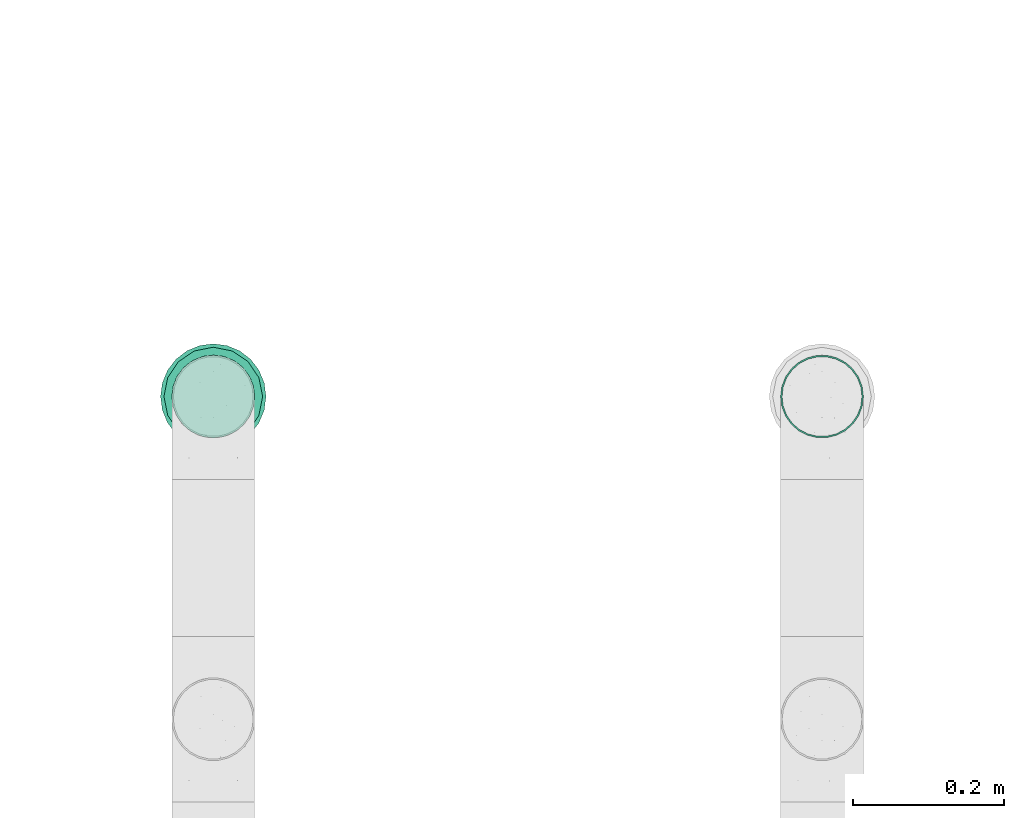
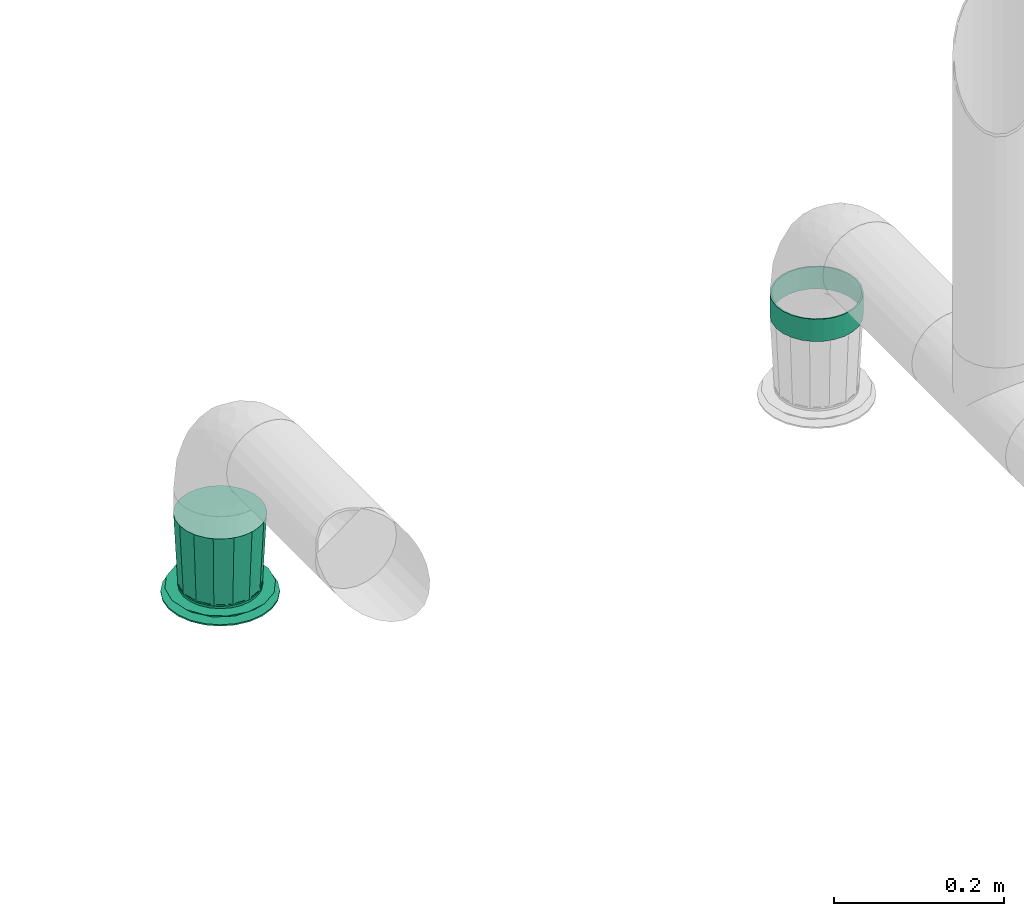
# One storey, part 33 of 103: 1 flow fitting, 1 flow segment, 1 flow terminal.
"""IFC2X3 building model written with IfcOpenShell, lengths in millimetres."""

from ifc_helpers import new_model, entity, si_unit, converted_unit, derived_unit, direction, frame, origin_with_axes, origin_2d_with_axis, place, context, subcontext, project, spatial, hollow_circle, extrude, open_shell, surface_model, source, transform, mapped, material, layer, layer_set, layer_usage, type_object, element, save


model = new_model("IFC2X3")

# Units and contexts
model_context = context("Model", 3, precision=1e-05, world=origin_with_axes(), true_north=direction((0.0, 1.0)))
body_context = subcontext(model_context, "Body", "Model", "MODEL_VIEW")
ifc_project = project(units=[si_unit("AREAUNIT", "SQUARE_METRE"), si_unit("VOLUMEUNIT", "CUBIC_METRE", prefix="DECI"), si_unit("TIMEUNIT", "SECOND"), si_unit("THERMODYNAMICTEMPERATUREUNIT", "DEGREE_CELSIUS"), si_unit("PRESSUREUNIT", "PASCAL"), si_unit("MASSUNIT", "GRAM", prefix="KILO"), si_unit("LENGTHUNIT", "METRE", prefix="MILLI"), si_unit("POWERUNIT", "WATT"), si_unit("ELECTRICCURRENTUNIT", "AMPERE"), si_unit("ELECTRICVOLTAGEUNIT", "VOLT"), derived_unit("VOLUMETRICFLOWRATEUNIT", [(si_unit("VOLUMEUNIT", "CUBIC_METRE", prefix="DECI"), 1), (si_unit("TIMEUNIT", "SECOND"), -1)]), derived_unit("LINEARVELOCITYUNIT", [(si_unit("LENGTHUNIT", "METRE"), 1), (si_unit("TIMEUNIT", "SECOND"), -1)]), derived_unit("MASSDENSITYUNIT", [(si_unit("MASSUNIT", "GRAM", prefix="KILO"), 1), (si_unit("VOLUMEUNIT", "CUBIC_METRE"), -1)]), converted_unit("PLANEANGLEUNIT", "DEGREE", entity("IfcRatioMeasure", 0.01745), si_unit("PLANEANGLEUNIT", "RADIAN"), dimensions=[0, 0, 0, 0, 0, 0, 0])], contexts=[model_context])

# Site, building, storey
site_placement = place(None, origin_with_axes())
site = spatial("IfcSite", under=ifc_project, at=site_placement, CompositionType="ELEMENT")
building_placement = place(site_placement, origin_with_axes())
building = spatial("IfcBuilding", under=site, at=building_placement, Name="mc-building", CompositionType="ELEMENT")
storey_placement = place(building_placement, frame((0.0, 0.0, 5900.0), z_axis=(0.0, 0.0, 1.0), x_axis=(1.0, 0.0, 0.0)))
storey = spatial("IfcBuildingStorey", under=building, at=storey_placement, Name="3. Korrus", CompositionType="ELEMENT", Elevation=5900.0)

# Flow segment
ifc_material = material(Name="FZ1")
ifc_layer = layer(ifc_material, 0.0)
ifc_layer_set = layer_set([ifc_layer], Name="FZ1")
ifc_layer_usage = layer_usage(ifc_layer_set, "AXIS1", "POSITIVE", 0.0)
duct_segment_type = type_object("IfcDuctSegmentType", PredefinedType="RIGIDSEGMENT")
shared_shape_1 = source(origin_with_axes(), body_context, "Body", "SweptSolid", [
    extrude(hollow_circle(Radius=55.0, WallThickness=2.0, at=origin_2d_with_axis()), frame((0.0, 0.0, 0.0), z_axis=(1.0, 0.0, 0.0), x_axis=(0.0, 1.0, 0.0)), (0.0, 0.0, 1.0), 31.9),
])
flow_segment_placement = place(storey_placement, frame((16394.13313, 4730.85862, 2235.0), z_axis=(0.0, -1.0, 0.0), x_axis=(0.0, 0.0, -1.0)))
element("IfcFlowSegment", 1, at=flow_segment_placement, inside=storey, type_object=duct_segment_type, material=ifc_layer_usage, context=body_context, shape_type="MappedRepresentation", body=[
    mapped(shared_shape_1, transform((0.0, 0.0, 0.0), scale=1.0)),
])

# Flow terminal
air_terminal_type = type_object("IfcAirTerminalType", Name="100", PredefinedType="NOTDEFINED")
shared_shape_2 = source(origin_with_axes(), body_context, "Body", "SurfaceModel", [
    surface_model("IfcShellBasedSurfaceModel", [(11.2, -70.0, 0.0), (11.2, -67.61481, -18.11733), (11.2, -67.61481, 18.11733), (6.2, -14.64625, -20.15883), (9.2, -22.36867, -22.36867), (6.2, -21.19625, -15.39997), (9.2, 16.375, -28.36233), (6.2, 8.09625, -24.91768), (6.2, 14.64625, -20.15883), (6.2, -8.09625, -24.91768), (9.2, -16.375, -28.36233), (6.2, 21.19625, -15.39997), (9.2, 22.36867, -22.36867), (9.2, -8.1875, -30.55617), (9.2, 8.1875, -30.55617), (9.2, 28.36233, -16.375), (9.2, -28.36233, -16.375), (6.2, 14.64625, 20.15883), (9.2, 22.36867, 22.36867), (6.2, 21.19625, 15.39997), (9.2, -16.375, 28.36233), (6.2, -8.09625, 24.91768), (6.2, -14.64625, 20.15883), (6.2, 8.09625, 24.91768), (9.2, 16.375, 28.36233), (6.2, -21.19625, 15.39997), (9.2, -22.36867, 22.36867), (9.2, 8.1875, 30.55617), (9.2, -8.1875, 30.55617), (9.2, -28.36233, 16.375), (9.2, 28.36233, 16.375), (6.2, -53.11211, -25.57744), (6.2, -36.75472, -46.08897), (6.2, -13.11761, -57.472), (6.2, 13.11761, -57.472), (6.2, 36.75472, -46.08897), (6.2, 53.11211, -25.57744), (0.0, -12.53288, -63.00706), (6.2, 0.0, -57.472), (0.0, -46.3155, -46.3155), (0.0, -35.69063, -53.4148), (0.0, 0.0, -65.5), (6.2, 44.93342, -35.83321), (0.0, 46.3155, -46.3155), (0.0, 35.69063, -53.4148), (6.2, -44.93342, -35.83321), (0.0, 12.53288, -63.00706), (0.0, 25.06576, -60.51411), (6.2, 56.03105, -12.78872), (0.0, 60.51411, -25.06576), (0.0, 63.00706, -12.53288), (0.0, 53.4148, -35.69063), (0.0, -25.06576, -60.51411), (0.0, -63.00706, -12.53288), (0.0, -60.51411, -25.06576), (6.2, -56.03105, -12.78872), (0.0, -53.4148, -35.69063), (6.2, 13.11761, 57.472), (0.0, 12.53288, 63.00706), (6.2, 0.0, 57.472), (6.2, 36.75472, 46.08897), (0.0, 46.3155, 46.3155), (0.0, 35.69063, 53.4148), (0.0, 0.0, 65.5), (6.2, -44.93342, 35.83321), (6.2, -36.75472, 46.08897), (0.0, -46.3155, 46.3155), (0.0, -35.69063, 53.4148), (6.2, 44.93342, 35.83321), (0.0, -12.53288, 63.00706), (0.0, -25.06576, 60.51411), (6.2, -13.11761, 57.472), (6.2, -56.03105, 12.78872), (0.0, -60.51411, 25.06576), (0.0, -63.00706, 12.53288), (0.0, -53.4148, 35.69063), (0.0, 25.06576, 60.51411), (0.0, 63.00706, 12.53288), (0.0, 60.51411, 25.06576), (6.2, 56.03105, 12.78872), (0.0, 53.4148, 35.69063), (-3.1, 43.30127, 25.0), (-3.1, -48.29629, -12.94095), (-3.1, -43.30127, 25.0), (-3.1, 25.0, -43.30127), (-3.1, 48.29629, -12.94095), (-3.1, 35.35534, -35.35534), (-3.1, -35.35534, -35.35534), (-3.1, -25.0, -43.30127), (-43.1, 43.46666, 11.64686), (-3.1, 38.97115, 22.5), (-3.1, 43.46666, 11.64686), (-3.1, 45.0, 0.0), (-43.1, 45.0, 0.0), (-3.1, 31.81981, 31.81981), (-43.1, 38.97115, 22.5), (-43.1, -38.97115, 22.5), (-3.1, -38.97115, 22.5), (-3.1, -31.81981, 31.81981), (-3.1, -43.46666, 11.64686), (-43.1, -43.46666, 11.64686), (-43.1, -45.0, 0.0), (-3.1, -45.0, 0.0), (-43.1, -43.46666, -11.64686), (-3.1, -38.97115, -22.5), (-3.1, -43.46666, -11.64686), (-3.1, -11.64686, -43.46666), (-3.1, -22.5, -38.97115), (-43.1, -22.5, -38.97115), (-3.1, -31.81981, -31.81981), (-43.1, -38.97115, -22.5), (-43.1, 22.5, -38.97115), (-3.1, 22.5, -38.97115), (-3.1, 11.64686, -43.46666), (-43.1, 38.97115, -22.5), (-3.1, 38.97115, -22.5), (-3.1, 31.81981, -31.81981), (-3.1, 43.46666, -11.64686), (-43.1, 43.46666, -11.64686), (11.2, -49.49747, -49.49747), (11.2, -35.0, -60.62178), (11.2, -18.11733, -67.61481), (11.2, 67.61481, 18.11733), (11.2, -60.62178, -35.0), (11.2, 18.11733, -67.61481), (11.2, 35.0, -60.62178), (11.2, 0.0, -70.0), (11.2, 60.62178, -35.0), (11.2, 67.61481, -18.11733), (11.2, 49.49747, -49.49747), (11.2, -49.49747, 49.49747), (11.2, -60.62178, 35.0), (11.2, -35.0, 60.62178), (11.2, -18.11733, 67.61481), (11.2, 0.0, 70.0), (11.2, 60.62178, 35.0), (11.2, 49.49747, 49.49747), (11.2, 70.0, 0.0), (11.2, 35.0, 60.62178), (11.2, 18.11733, 67.61481), (9.2, -49.49747, 49.49747), (9.2, -35.0, 60.62178), (9.2, -18.11733, 67.61481), (9.2, -67.61481, 18.11733), (9.2, -70.0, 0.0), (9.2, -60.62178, 35.0), (9.2, 67.61481, 18.11733), (9.2, 35.0, 60.62178), (9.2, 18.11733, 67.61481), (9.2, 0.0, 70.0), (9.2, 60.62178, 35.0), (9.2, 49.49747, 49.49747), (9.2, -67.61481, -18.11733), (9.2, -49.49747, -49.49747), (9.2, -60.62178, -35.0), (9.2, -18.11733, -67.61481), (9.2, 70.0, 0.0), (9.2, -35.0, -60.62178), (9.2, 0.0, -70.0), (9.2, 60.62178, -35.0), (9.2, 49.49747, -49.49747), (9.2, 67.61481, -18.11733), (9.2, 35.0, -60.62178), (9.2, 18.11733, -67.61481), (9.2, -32.75, 0.0), (9.2, 0.0, 32.75), (9.2, 32.75, 0.0), (9.2, 0.0, -32.75), (6.2, 26.2, 0.0), (6.2, -26.2, 0.0), (9.2, -31.06579, -6.28555), (6.2, -23.69812, -7.69999), (6.2, 23.69812, -7.69999), (9.2, 31.06579, -6.28555), (6.2, 0.0, -24.91768), (9.2, 31.06579, 6.28555), (6.2, 23.69812, 7.69999), (6.2, -23.69812, 7.69999), (9.2, -31.06579, 6.28555), (6.2, 0.0, 24.91768), (6.2, 53.11211, 25.57744), (6.2, 58.95, 0.0), (6.2, -53.11211, 25.57744), (6.2, -58.95, 0.0), (0.0, 65.5, 0.0), (0.0, -65.5, 0.0), (6.2, -24.93616, -51.78048), (6.2, 24.93616, -51.78048), (6.2, 24.93616, 51.78048), (6.2, -24.93616, 51.78048), (-3.1, 0.0, 50.0), (-3.1, 35.35534, 35.35534), (-3.1, -12.94095, 48.29629), (-3.1, -25.0, 43.30127), (-3.1, -35.35534, 35.35534), (-3.1, 25.0, 43.30127), (-3.1, 12.94095, 48.29629), (-3.1, 48.29629, 12.94095), (-3.1, 50.0, 0.0), (-3.1, -50.0, 0.0), (-3.1, -48.29629, 12.94095), (-3.1, -43.30127, -25.0), (-3.1, -12.94095, -48.29629), (-3.1, 0.0, -50.0), (-3.1, 43.30127, -25.0), (-3.1, 12.94095, -48.29629), (0.0, -12.94095, -48.29629), (0.0, 0.0, -50.0), (0.0, -25.0, -43.30127), (0.0, -35.35534, -35.35534), (0.0, -48.29629, -12.94095), (0.0, 25.0, -43.30127), (0.0, -43.30127, -25.0), (0.0, 43.30127, 25.0), (0.0, 12.94095, -48.29629), (0.0, 43.30127, -25.0), (0.0, 48.29629, -12.94095), (0.0, 35.35534, -35.35534), (0.0, 50.0, 0.0), (0.0, -50.0, 0.0), (0.0, -48.29629, 12.94095), (0.0, -43.30127, 25.0), (0.0, -35.35534, 35.35534), (0.0, -12.94095, 48.29629), (0.0, -25.0, 43.30127), (0.0, 35.35534, 35.35534), (0.0, 0.0, 50.0), (0.0, 48.29629, 12.94095), (0.0, 25.0, 43.30127), (0.0, 12.94095, 48.29629), (-43.1, -22.5, 38.97115), (-43.1, -11.64686, 43.46666), (-43.1, 0.0, 45.0), (-43.1, 11.64686, 43.46666), (-43.1, -31.81981, 31.81981), (-43.1, 31.81981, 31.81981), (-43.1, 22.5, 38.97115), (-43.1, -31.81981, -31.81981), (-43.1, 31.81981, -31.81981), (-43.1, -11.64686, -43.46666), (-43.1, 11.64686, -43.46666), (-43.1, 0.0, -45.0), (-3.1, 0.0, -45.0), (-3.1, 0.0, 45.0), (-3.1, -22.5, 38.97115), (-3.1, -11.64686, 43.46666), (-3.1, 11.64686, 43.46666), (-3.1, 22.5, 38.97115)], [open_shell([[[0, 1, 2]], [[3, 4, 5]], [[6, 7, 8]], [[3, 9, 10]], [[4, 3, 10]], [[11, 12, 8]], [[13, 10, 9]], [[7, 6, 14]], [[6, 8, 12]], [[12, 11, 15]], [[16, 5, 4]], [[17, 18, 19]], [[20, 21, 22]], [[17, 23, 24]], [[18, 17, 24]], [[25, 26, 22]], [[27, 24, 23]], [[21, 20, 28]], [[20, 22, 26]], [[26, 25, 29]], [[30, 19, 18]], [[31, 32, 33]], [[34, 35, 36]], [[33, 37, 38]], [[32, 39, 40]], [[41, 38, 37]], [[42, 35, 43]], [[44, 43, 35]], [[39, 32, 45]], [[46, 47, 34]], [[48, 49, 50]], [[38, 46, 34]], [[42, 43, 51]], [[33, 52, 37]], [[53, 54, 55]], [[46, 38, 41]], [[56, 39, 45]], [[57, 58, 59]], [[60, 61, 62]], [[63, 59, 58]], [[64, 65, 66]], [[67, 66, 65]], [[61, 60, 68]], [[69, 70, 71]], [[72, 73, 74]], [[59, 69, 71]], [[64, 66, 75]], [[57, 76, 58]], [[77, 78, 79]], [[69, 59, 63]], [[80, 61, 68]], [[81, 82, 83]], [[84, 85, 86]], [[87, 82, 88]], [[89, 90, 91]], [[91, 92, 93]], [[94, 90, 95]], [[96, 97, 98]], [[99, 97, 100]], [[101, 102, 99]], [[103, 104, 105]], [[105, 102, 101]], [[106, 107, 108]], [[109, 104, 110]], [[111, 112, 113]], [[114, 115, 116]], [[117, 115, 118]], [[93, 92, 117]], [[119, 120, 121]], [[1, 119, 121]], [[122, 1, 121]], [[123, 119, 1]], [[124, 122, 121]], [[125, 122, 124]], [[121, 126, 124]], [[127, 128, 129]], [[129, 128, 122]], [[129, 122, 125]], [[130, 131, 2]], [[132, 130, 2]], [[122, 133, 2]], [[132, 2, 133]], [[134, 133, 122]], [[135, 136, 122]], [[122, 128, 137]], [[136, 138, 122]], [[139, 122, 138]], [[122, 139, 134]], [[2, 1, 122]], [[140, 141, 142]], [[143, 140, 142]], [[142, 144, 143]], [[145, 140, 143]], [[146, 144, 142]], [[147, 146, 148]], [[149, 148, 146]], [[150, 146, 151]], [[147, 151, 146]], [[146, 142, 149]], [[146, 152, 144]], [[153, 154, 152]], [[155, 153, 152]], [[146, 156, 155]], [[157, 153, 155]], [[158, 155, 156]], [[159, 160, 161]], [[156, 161, 160]], [[160, 162, 156]], [[163, 156, 162]], [[163, 158, 156]], [[152, 146, 155]], [[156, 128, 161]], [[161, 127, 159]], [[162, 160, 125]], [[129, 160, 159]], [[163, 162, 124]], [[128, 127, 161]], [[156, 137, 128]], [[162, 125, 124]], [[125, 160, 129]], [[159, 127, 129]], [[163, 124, 126]], [[126, 158, 163]], [[158, 121, 155]], [[155, 120, 157]], [[154, 153, 123]], [[119, 153, 157]], [[152, 154, 1]], [[120, 119, 157]], [[155, 121, 120]], [[152, 1, 0]], [[1, 154, 123]], [[153, 119, 123]], [[152, 0, 144]], [[126, 121, 158]], [[144, 2, 143]], [[143, 131, 145]], [[141, 140, 132]], [[130, 140, 145]], [[142, 141, 133]], [[2, 131, 143]], [[144, 0, 2]], [[141, 132, 133]], [[132, 140, 130]], [[145, 131, 130]], [[142, 133, 134]], [[134, 149, 142]], [[149, 139, 148]], [[148, 138, 147]], [[150, 151, 135]], [[136, 151, 147]], [[146, 150, 122]], [[138, 136, 147]], [[148, 139, 138]], [[146, 122, 137]], [[122, 150, 135]], [[151, 136, 135]], [[146, 137, 156]], [[134, 139, 149]], [[30, 24, 164]], [[24, 20, 164]], [[165, 20, 24]], [[164, 20, 29]], [[166, 30, 16]], [[16, 6, 166]], [[167, 6, 10]], [[30, 164, 16]], [[10, 6, 16]], [[6, 15, 166]], [[21, 19, 11]], [[23, 19, 21]], [[11, 19, 168]], [[7, 25, 21]], [[7, 5, 169]], [[21, 11, 7]], [[9, 5, 7]], [[169, 25, 7]], [[170, 164, 169]], [[170, 171, 16]], [[11, 172, 15]], [[172, 168, 173]], [[174, 13, 9]], [[166, 173, 168]], [[172, 173, 15]], [[169, 171, 170]], [[5, 16, 171]], [[167, 174, 14]], [[174, 167, 13]], [[14, 174, 7]], [[175, 166, 168]], [[175, 176, 30]], [[25, 177, 29]], [[177, 169, 178]], [[179, 27, 23]], [[164, 178, 169]], [[177, 178, 29]], [[168, 176, 175]], [[19, 30, 176]], [[165, 179, 28]], [[179, 165, 27]], [[28, 179, 21]], [[180, 60, 57]], [[181, 180, 65]], [[65, 57, 71]], [[180, 57, 65]], [[65, 182, 181]], [[182, 36, 181]], [[183, 34, 36]], [[31, 34, 183]], [[31, 33, 34]], [[182, 183, 36]], [[70, 63, 49]], [[70, 73, 66]], [[49, 63, 184]], [[78, 76, 61]], [[76, 78, 184]], [[184, 63, 76]], [[73, 70, 49]], [[39, 54, 185]], [[41, 39, 185]], [[52, 39, 41]], [[43, 185, 49]], [[185, 43, 47]], [[185, 47, 41]], [[73, 49, 185]], [[55, 54, 31]], [[31, 54, 56]], [[52, 186, 40]], [[53, 55, 183]], [[56, 45, 31]], [[185, 53, 183]], [[32, 40, 186]], [[33, 186, 52]], [[44, 35, 187]], [[49, 36, 51]], [[34, 47, 187]], [[42, 51, 36]], [[187, 47, 44]], [[49, 48, 36]], [[48, 50, 181]], [[184, 181, 50]], [[79, 78, 180]], [[180, 78, 80]], [[76, 188, 62]], [[77, 79, 181]], [[80, 68, 180]], [[184, 77, 181]], [[60, 62, 188]], [[57, 188, 76]], [[67, 65, 189]], [[73, 182, 75]], [[71, 70, 189]], [[64, 75, 182]], [[189, 70, 67]], [[73, 72, 182]], [[72, 74, 183]], [[185, 183, 74]], [[190, 191, 192]], [[193, 192, 194]], [[83, 192, 81]], [[194, 192, 83]], [[195, 191, 196]], [[191, 190, 196]], [[197, 198, 81]], [[81, 192, 191]], [[198, 84, 81]], [[199, 200, 83]], [[81, 88, 82]], [[201, 82, 87]], [[88, 81, 202]], [[81, 203, 202]], [[204, 86, 85]], [[205, 203, 84]], [[84, 198, 85]], [[81, 84, 203]], [[199, 83, 82]], [[206, 207, 208]], [[209, 208, 210]], [[210, 208, 211]], [[212, 209, 210]], [[210, 211, 213]], [[214, 211, 207]], [[211, 208, 207]], [[215, 216, 217]], [[211, 217, 216]], [[216, 218, 211]], [[219, 210, 220]], [[221, 210, 213]], [[222, 221, 223]], [[213, 223, 221]], [[224, 222, 223]], [[223, 225, 226]], [[227, 213, 218]], [[218, 213, 211]], [[228, 229, 225]], [[223, 213, 225]], [[226, 225, 229]], [[221, 220, 210]], [[199, 220, 200]], [[200, 221, 83]], [[193, 194, 224]], [[222, 194, 83]], [[192, 193, 223]], [[220, 221, 200]], [[199, 219, 220]], [[193, 224, 223]], [[224, 194, 222]], [[83, 221, 222]], [[192, 223, 226]], [[226, 190, 192]], [[190, 229, 196]], [[196, 228, 195]], [[81, 191, 213]], [[225, 191, 195]], [[197, 81, 227]], [[228, 225, 195]], [[196, 229, 228]], [[197, 227, 218]], [[227, 81, 213]], [[191, 225, 213]], [[197, 218, 198]], [[226, 229, 190]], [[198, 216, 85]], [[85, 215, 204]], [[84, 86, 211]], [[217, 86, 204]], [[205, 84, 214]], [[216, 215, 85]], [[198, 218, 216]], [[84, 211, 214]], [[211, 86, 217]], [[204, 215, 217]], [[205, 214, 207]], [[207, 203, 205]], [[203, 206, 202]], [[202, 208, 88]], [[201, 87, 212]], [[209, 87, 88]], [[82, 201, 210]], [[208, 209, 88]], [[202, 206, 208]], [[82, 210, 219]], [[210, 201, 212]], [[87, 209, 212]], [[82, 219, 199]], [[207, 206, 203]], [[230, 231, 232]], [[230, 232, 233]], [[230, 100, 96]], [[234, 230, 96]], [[100, 230, 233]], [[235, 89, 236]], [[100, 233, 236]], [[95, 89, 235]], [[118, 89, 93]], [[118, 236, 89]], [[118, 100, 236]], [[110, 103, 101]], [[237, 110, 101]], [[238, 108, 101]], [[237, 101, 108]], [[239, 108, 238]], [[114, 238, 118]], [[238, 101, 118]], [[240, 241, 111]], [[238, 111, 241]], [[238, 241, 239]], [[100, 118, 101]], [[106, 242, 107]], [[107, 112, 109]], [[102, 105, 104]], [[112, 104, 109]], [[92, 104, 117]], [[113, 112, 242]], [[112, 107, 242]], [[115, 117, 116]], [[112, 116, 117]], [[112, 117, 104]], [[92, 102, 104]], [[97, 99, 243]], [[98, 97, 244]], [[243, 245, 244]], [[97, 243, 244]], [[246, 243, 99]], [[90, 94, 91]], [[92, 91, 247]], [[94, 247, 91]], [[247, 99, 92]], [[247, 246, 99]], [[102, 92, 99]], [[101, 99, 100]], [[100, 97, 96]], [[230, 234, 244]], [[98, 234, 96]], [[231, 230, 245]], [[245, 230, 244]], [[244, 234, 98]], [[245, 243, 231]], [[243, 232, 231]], [[236, 233, 246]], [[236, 247, 235]], [[89, 95, 90]], [[94, 95, 235]], [[93, 89, 91]], [[232, 246, 233]], [[246, 247, 236]], [[243, 246, 232]], [[247, 94, 235]], [[93, 117, 118]], [[118, 115, 114]], [[111, 238, 112]], [[116, 238, 114]], [[240, 111, 113]], [[112, 238, 116]], [[240, 113, 242]], [[242, 241, 240]], [[108, 239, 106]], [[108, 107, 237]], [[103, 110, 104]], [[109, 110, 237]], [[101, 103, 105]], [[241, 106, 239]], [[242, 106, 241]], [[107, 109, 237]]])]),
])
flow_terminal_placement = place(storey_placement, frame((15585.80789, 4730.85862, 2100.0), z_axis=(0.0, -1.0, 0.0), x_axis=(0.0, 0.0, -1.0)))
element("IfcFlowTerminal", 2, at=flow_terminal_placement, inside=storey, type_object=air_terminal_type, Name="100", context=body_context, shape_type="MappedRepresentation", body=[
    mapped(shared_shape_2, transform((0.0, 0.0, 0.0), scale=1.0)),
])

# Flow fitting
duct_fitting_type = type_object("IfcDuctFittingType", PredefinedType="TRANSITION")
shared_shape_3 = source(origin_with_axes(), body_context, "Body", "SurfaceModel", [
    surface_model("IfcShellBasedSurfaceModel", [(100.0, -55.0, 0.0), (100.0, -12.23865, 53.62104), (100.0, -34.29194, 43.00073), (100.0, 49.55329, 23.86361), (100.0, 34.29194, 43.00073), (100.0, 49.55329, -23.86361), (0.0, -45.04844, -21.69419), (0.0, -50.0, 0.0), (0.0, -45.04844, 21.69419), (0.0, 31.17449, 39.09157), (0.0, 45.04844, 21.69419), (0.0, 50.0, 0.0), (98.0, 47.63139, 27.5), (98.0, 0.0, 55.0), (98.0, 38.89087, 38.89087), (98.0, -38.89087, 38.89087), (98.0, -47.63139, 27.5), (100.0, 12.23865, 53.62104), (100.0, -49.55329, 23.86361), (100.0, 55.0, 0.0), (100.0, 12.23865, -53.62104), (100.0, 34.29194, -43.00073), (100.0, -49.55329, -23.86361), (100.0, -34.29194, -43.00073), (100.0, -12.23865, -53.62104), (0.0, -31.17449, 39.09157), (0.0, -11.12605, 48.7464), (0.0, 11.12605, 48.7464), (0.0, -31.17449, -39.09157), (0.0, 11.12605, -48.7464), (0.0, -11.12605, -48.7464), (0.0, 45.04844, -21.69419), (0.0, 31.17449, -39.09157), (0.0, 47.52422, -10.84709), (0.0, 38.11147, -30.39288), (100.0, 41.92261, -33.43217), (100.0, -41.92261, -33.43217), (0.0, -38.11147, -30.39288), (100.0, 23.2653, -48.31088), (0.0, 21.15027, -43.91899), (100.0, 52.32388, -11.72483), (0.0, 0.0, -48.7464), (100.0, 0.0, -53.62104), (0.0, -21.15027, -43.91899), (100.0, -23.2653, -48.31088), (0.0, -47.52422, -10.84709), (100.0, -52.32388, -11.72483), (0.0, -47.52422, 10.84709), (0.0, -38.11147, 30.39288), (100.0, -41.92261, 33.43217), (100.0, 41.92261, 33.43217), (0.0, 38.11147, 30.39288), (100.0, -23.2653, 48.31088), (0.0, -21.15027, 43.91899), (100.0, -52.32388, 11.72483), (0.0, 0.0, 48.7464), (100.0, 0.0, 53.62104), (0.0, 21.15027, 43.91899), (100.0, 23.2653, 48.31088), (0.0, 47.52422, 10.84709), (100.0, 52.32388, 11.72483), (100.0, -14.23505, -53.12592), (100.0, 0.0, -55.0), (100.0, -27.5, -47.63139), (100.0, 27.5, -47.63139), (100.0, -38.89087, -38.89087), (100.0, -53.12592, -14.23505), (100.0, -47.63139, -27.5), (100.0, -47.63139, 27.5), (100.0, 14.23505, -53.12592), (100.0, 38.89087, -38.89087), (100.0, 47.63139, -27.5), (100.0, 47.63139, 27.5), (100.0, 53.12592, -14.23505), (100.0, -53.12592, 14.23505), (100.0, -38.89087, 38.89087), (100.0, -27.5, 47.63139), (100.0, 0.0, 55.0), (100.0, -14.23505, 53.12592), (100.0, 53.12592, 14.23505), (100.0, 38.89087, 38.89087), (100.0, 27.5, 47.63139), (100.0, 14.23505, 53.12592), (98.0, -27.5, 47.63139), (98.0, -14.23505, 53.12592), (98.0, -53.12592, -14.23505), (98.0, 14.23505, 53.12592), (98.0, 27.5, 47.63139), (98.0, 53.12592, 14.23505), (98.0, 55.0, 0.0), (98.0, -47.63139, -27.5), (98.0, -53.12592, 14.23505), (98.0, 27.5, -47.63139), (98.0, -27.5, -47.63139), (98.0, -38.89087, -38.89087), (98.0, 0.0, -55.0), (98.0, -14.23505, -53.12592), (98.0, 38.89087, -38.89087), (98.0, 47.63139, -27.5), (98.0, 53.12592, -14.23505), (98.0, 14.23505, -53.12592), (98.0, -55.0, 0.0), (0.0, 0.0, 50.0), (0.0, 35.35534, 35.35534), (0.0, -12.94095, 48.29629), (0.0, -25.0, 43.30127), (0.0, -35.35534, 35.35534), (0.0, -48.29629, 12.94095), (0.0, -43.30127, 25.0), (0.0, 25.0, 43.30127), (0.0, 12.94095, 48.29629), (0.0, 43.30127, 25.0), (0.0, 48.29629, 12.94095), (0.0, 25.0, -43.30127), (0.0, 48.29629, -12.94095), (0.0, -48.29629, -12.94095), (0.0, -43.30127, -25.0), (0.0, -12.94095, -48.29629), (0.0, -25.0, -43.30127), (0.0, -35.35534, -35.35534), (0.0, 43.30127, -25.0), (0.0, 35.35534, -35.35534), (0.0, 12.94095, -48.29629), (0.0, 0.0, -50.0), (2.0, -35.35534, -35.35534), (2.0, -25.0, -43.30127), (2.0, -12.94095, -48.29629), (2.0, -43.30127, -25.0), (2.0, 0.0, -50.0), (2.0, -48.29629, -12.94095), (2.0, -50.0, 0.0), (2.0, 12.94095, -48.29629), (2.0, 25.0, -43.30127), (2.0, 43.30127, -25.0), (2.0, 48.29629, -12.94095), (2.0, 35.35534, -35.35534), (2.0, -48.29629, 12.94095), (2.0, -35.35534, 35.35534), (2.0, -43.30127, 25.0), (2.0, 35.35534, 35.35534), (2.0, -12.94095, 48.29629), (2.0, -25.0, 43.30127), (2.0, 0.0, 50.0), (2.0, 43.30127, 25.0), (2.0, 48.29629, 12.94095), (2.0, 50.0, 0.0), (2.0, 25.0, 43.30127), (2.0, 12.94095, 48.29629)], [open_shell([[[0, 1, 2]], [[3, 4, 5]], [[6, 7, 8]], [[9, 10, 11]], [[12, 13, 14]], [[15, 13, 16]], [[0, 4, 17]], [[2, 18, 0]], [[1, 0, 17]], [[3, 5, 19]], [[20, 21, 5]], [[22, 20, 5]], [[22, 5, 0]], [[22, 23, 24]], [[22, 24, 20]], [[4, 0, 5]], [[8, 25, 6]], [[6, 25, 26]], [[6, 26, 27]], [[11, 27, 9]], [[28, 6, 29]], [[30, 28, 29]], [[31, 6, 11]], [[31, 32, 29]], [[31, 29, 6]], [[27, 11, 6]], [[31, 33, 5]], [[34, 35, 32]], [[36, 22, 6]], [[36, 37, 23]], [[38, 29, 39]], [[33, 40, 5]], [[33, 11, 40]], [[19, 40, 11]], [[32, 21, 39]], [[32, 35, 21]], [[34, 31, 35]], [[30, 41, 42]], [[28, 43, 44]], [[42, 41, 20]], [[7, 45, 46]], [[38, 39, 21]], [[46, 0, 7]], [[6, 37, 36]], [[38, 20, 29]], [[43, 30, 24]], [[42, 24, 30]], [[28, 23, 37]], [[6, 22, 45]], [[35, 31, 5]], [[44, 43, 24]], [[20, 41, 29]], [[46, 45, 22]], [[44, 23, 28]], [[8, 47, 18]], [[48, 49, 25]], [[50, 3, 10]], [[50, 51, 4]], [[52, 26, 53]], [[47, 54, 18]], [[47, 7, 54]], [[0, 54, 7]], [[25, 2, 53]], [[25, 49, 2]], [[48, 8, 49]], [[27, 55, 56]], [[9, 57, 58]], [[56, 55, 1]], [[11, 59, 60]], [[52, 53, 2]], [[60, 19, 11]], [[10, 51, 50]], [[52, 1, 26]], [[57, 27, 17]], [[56, 17, 27]], [[9, 4, 51]], [[10, 3, 59]], [[49, 8, 18]], [[58, 57, 17]], [[1, 55, 26]], [[60, 59, 3]], [[58, 4, 9]], [[61, 62, 63]], [[63, 64, 65]], [[66, 67, 68]], [[65, 64, 67]], [[67, 64, 68]], [[69, 64, 62]], [[64, 63, 62]], [[70, 71, 64]], [[72, 64, 71]], [[71, 73, 19]], [[74, 0, 66]], [[72, 68, 64]], [[75, 68, 76]], [[77, 78, 76]], [[72, 76, 68]], [[76, 72, 77]], [[79, 72, 19]], [[19, 72, 71]], [[80, 81, 77]], [[77, 72, 80]], [[82, 77, 81]], [[74, 66, 68]], [[83, 84, 13]], [[15, 83, 13]], [[12, 16, 13]], [[16, 12, 85]], [[86, 87, 13]], [[87, 14, 13]], [[88, 89, 12]], [[89, 90, 12]], [[91, 16, 85]], [[90, 85, 12]], [[89, 92, 90]], [[93, 94, 95]], [[95, 94, 90]], [[96, 93, 95]], [[97, 92, 98]], [[98, 89, 99]], [[100, 95, 92]], [[92, 89, 98]], [[90, 92, 95]], [[101, 91, 85]], [[89, 73, 99]], [[99, 71, 98]], [[92, 97, 64]], [[70, 97, 98]], [[100, 92, 69]], [[73, 71, 99]], [[89, 19, 73]], [[92, 64, 69]], [[64, 97, 70]], [[98, 71, 70]], [[100, 69, 62]], [[62, 95, 100]], [[95, 61, 96]], [[96, 63, 93]], [[90, 94, 67]], [[65, 94, 93]], [[85, 90, 66]], [[63, 65, 93]], [[96, 61, 63]], [[85, 66, 0]], [[66, 90, 67]], [[94, 65, 67]], [[85, 0, 101]], [[62, 61, 95]], [[101, 74, 91]], [[91, 68, 16]], [[83, 15, 76]], [[75, 15, 16]], [[84, 83, 78]], [[74, 68, 91]], [[101, 0, 74]], [[83, 76, 78]], [[76, 15, 75]], [[16, 68, 75]], [[84, 78, 77]], [[77, 13, 84]], [[13, 82, 86]], [[86, 81, 87]], [[12, 14, 72]], [[80, 14, 87]], [[88, 12, 79]], [[81, 80, 87]], [[86, 82, 81]], [[88, 79, 19]], [[79, 12, 72]], [[14, 80, 72]], [[88, 19, 89]], [[77, 82, 13]], [[102, 103, 104]], [[105, 104, 106]], [[107, 108, 106]], [[103, 106, 104]], [[106, 103, 107]], [[109, 103, 110]], [[103, 102, 110]], [[111, 112, 103]], [[113, 103, 112]], [[112, 11, 114]], [[107, 103, 113]], [[113, 115, 107]], [[116, 115, 117]], [[117, 118, 119]], [[116, 117, 119]], [[117, 115, 113]], [[120, 121, 114]], [[113, 114, 121]], [[113, 122, 117]], [[113, 112, 114]], [[117, 122, 123]], [[7, 107, 115]], [[124, 125, 126]], [[127, 124, 126]], [[128, 129, 126]], [[127, 126, 129]], [[130, 129, 128]], [[131, 132, 128]], [[132, 130, 128]], [[133, 134, 135]], [[132, 135, 134]], [[132, 134, 130]], [[134, 136, 130]], [[137, 138, 136]], [[137, 136, 139]], [[140, 137, 139]], [[141, 137, 140]], [[142, 140, 139]], [[143, 139, 144]], [[144, 134, 145]], [[146, 147, 139]], [[139, 136, 144]], [[139, 147, 142]], [[136, 134, 144]], [[11, 134, 114]], [[114, 133, 120]], [[113, 121, 132]], [[135, 121, 120]], [[122, 113, 131]], [[134, 133, 114]], [[11, 145, 134]], [[113, 132, 131]], [[132, 121, 135]], [[120, 133, 135]], [[122, 131, 128]], [[128, 123, 122]], [[123, 126, 117]], [[117, 125, 118]], [[116, 119, 127]], [[124, 119, 118]], [[115, 116, 129]], [[125, 124, 118]], [[117, 126, 125]], [[115, 129, 130]], [[129, 116, 127]], [[119, 124, 127]], [[115, 130, 7]], [[128, 126, 123]], [[7, 136, 107]], [[107, 138, 108]], [[105, 106, 141]], [[137, 106, 108]], [[104, 105, 140]], [[136, 138, 107]], [[7, 130, 136]], [[105, 141, 140]], [[141, 106, 137]], [[108, 138, 137]], [[104, 140, 142]], [[142, 102, 104]], [[102, 147, 110]], [[110, 146, 109]], [[111, 103, 143]], [[139, 103, 109]], [[112, 111, 144]], [[146, 139, 109]], [[110, 147, 146]], [[112, 144, 145]], [[144, 111, 143]], [[103, 139, 143]], [[112, 145, 11]], [[142, 147, 102]]])]),
])
flow_fitting_placement = place(storey_placement, frame((15585.80789, 4730.85862, 2103.1), z_axis=(0.0, -1.0, 0.0), x_axis=(0.0, 0.0, 1.0)))
element("IfcFlowFitting", 3, at=flow_fitting_placement, inside=storey, type_object=duct_fitting_type, context=body_context, shape_type="MappedRepresentation", body=[
    mapped(shared_shape_3, transform((0.0, 0.0, 0.0), scale=1.0)),
])

save(model, "model.ifc")
